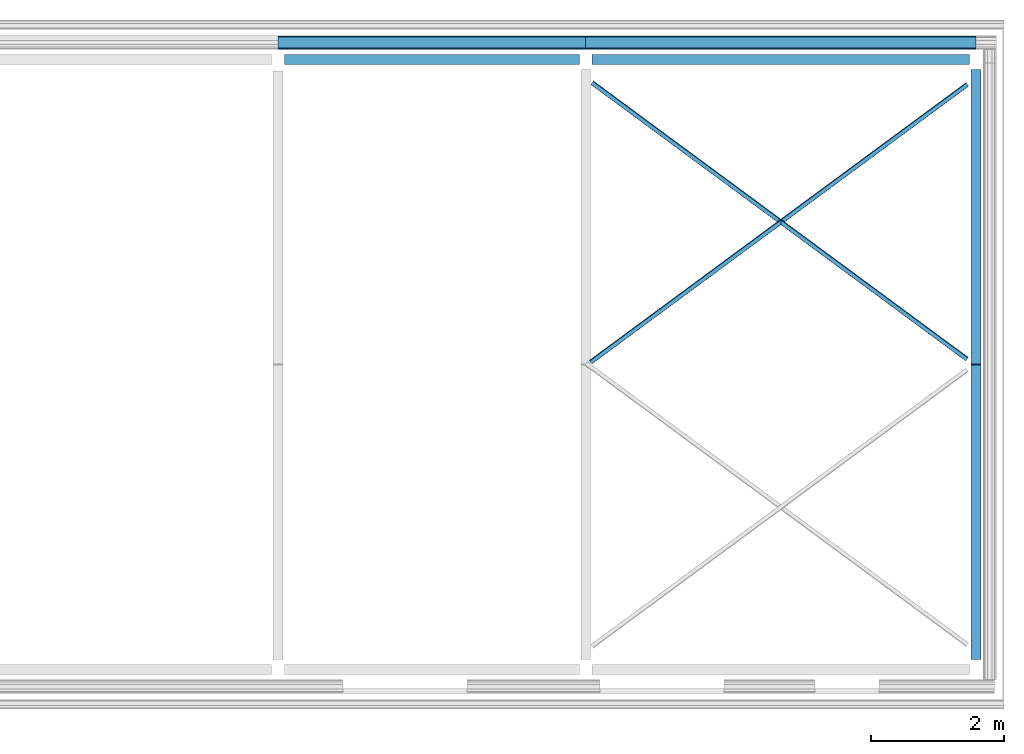
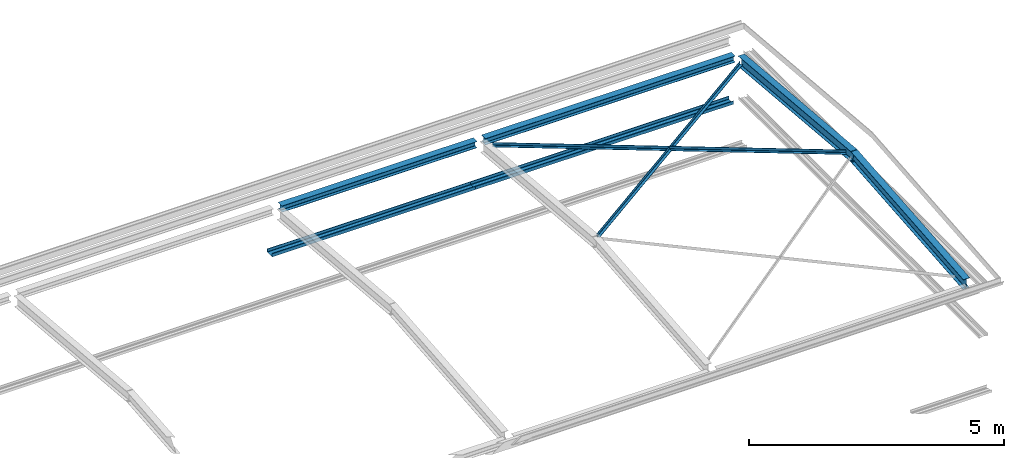
# One storey, part 3 of 8: 8 beams.
"""IFC2X3 building model written with IfcOpenShell, lengths in millimetres."""

from ifc_helpers import new_model, entity, si_unit, converted_unit, money_unit, point, direction, frame, frame_2d, origin_with_axes, place, context, subcontext, project, spatial, polyline, circle_curve, parameter, trimmed, segment, composite_curve, outline, extrude, clip, halfspace, material, type_object, element, save


model = new_model("IFC2X3")

# Units and contexts
model_context = context("Model", 3, precision=1e-05, world=origin_with_axes(), true_north=direction((0.0, 1.0)))
body_context = subcontext(model_context, "Body", "Model", "MODEL_VIEW")
ifc_project = project(units=[si_unit("LENGTHUNIT", "METRE", prefix="MILLI"), si_unit("AREAUNIT", "SQUARE_METRE"), si_unit("VOLUMEUNIT", "CUBIC_METRE"), converted_unit("PLANEANGLEUNIT", "DEGREE", entity("IfcPlaneAngleMeasure", 0.0174532925199), si_unit("PLANEANGLEUNIT", "RADIAN"), dimensions=[0, 0, 0, 0, 0, 0, 0]), si_unit("SOLIDANGLEUNIT", "STERADIAN"), money_unit("USD"), converted_unit("TIMEUNIT", "Year", entity("IfcTimeMeasure", 31556926.0), si_unit("TIMEUNIT", "SECOND"), dimensions=[0, 0, 0, 0, 0, 0, 0]), si_unit("MASSUNIT", "GRAM"), si_unit("THERMODYNAMICTEMPERATUREUNIT", "DEGREE_CELSIUS"), si_unit("LUMINOUSINTENSITYUNIT", "LUMEN")], contexts=[model_context])

# Site, building, storey
site_placement = place(None, origin_with_axes())
site = spatial("IfcSite", under=ifc_project, at=site_placement, CompositionType="ELEMENT")
building_placement = place(site_placement, origin_with_axes())
building = spatial("IfcBuilding", under=site, at=building_placement, CompositionType="ELEMENT")
storey_placement = place(building_placement, frame((0.0, 0.0, 74215.0), z_axis=(0.0, 0.0, 1.0), x_axis=(1.0, 0.0, 0.0)))
storey = spatial("IfcBuildingStorey", under=building, at=storey_placement, CompositionType="ELEMENT", Elevation=74215.0)

# Beams
ifc_material = material(Name="Metal - Steel 43-275")
beam_type_1 = type_object("IfcBeamType", Name="PFC200x75x23 (1) 75 x 200", PredefinedType="NOTDEFINED")
beam_1_placement = place(storey_placement, frame((10556.4431324, 8402.49616284, -1330.2), z_axis=(0.0, 0.0, 1.0), x_axis=(0.0, 1.0, 0.0)))
element("IfcBeam", 1, at=beam_1_placement, inside=storey, type_object=beam_type_1, material=ifc_material, Name="PFC-Parallel Flange Channels:PFC200x75x23", ObjectType="PFC-Parallel Flange Channels:PFC200x75x23", context=body_context, shape_type="SweptSolid", body=[
    extrude(outline(composite_curve([segment(polyline([(-40.2, -100.0), (34.8, -100.0), (34.8, 100.0), (-40.2, 100.0), (-40.2, 87.5), (16.8, 87.5)]), True, "CONTINUOUS"), segment(trimmed(circle_curve(frame_2d((16.8, 75.5), x_axis=(1.0, 0.0)), 12.0), [point((16.8, 87.5)), parameter(90.0)], [point((28.8, 75.5)), parameter(0.0)], False, "CARTESIAN"), True, "CONTINUOUS"), segment(polyline([(28.8, 75.5), (28.8, -75.5)]), True, "CONTINUOUS"), segment(trimmed(circle_curve(frame_2d((16.8, -75.5), x_axis=(0.0, -1.0)), 12.0), [point((28.8, -75.5)), parameter(90.0)], [point((16.8, -87.5)), parameter(0.0)], False, "CARTESIAN"), True, "CONTINUOUS"), segment(polyline([(16.8, -87.5), (-40.2, -87.5), (-40.2, -100.0)]), True, "CONTINUOUS")], self_intersect=False)), frame((0.0, 4610.24734375, 0.0), z_axis=(0.0, -1.0, 0.0), x_axis=(0.0, 0.0, -1.0)), (0.0, 0.0, 1.0), 4610.24734375),
])
beam_2_placement = place(storey_placement, frame((16408.2794762, 8402.49616284, -1330.2), z_axis=(0.0, 0.0, 1.0), x_axis=(0.0, 1.0, 0.0)))
element("IfcBeam", 2, at=beam_2_placement, inside=storey, type_object=beam_type_1, material=ifc_material, Name="PFC-Parallel Flange Channels:PFC200x75x23", ObjectType="PFC-Parallel Flange Channels:PFC200x75x23", context=body_context, shape_type="SweptSolid", body=[
    extrude(outline(composite_curve([segment(polyline([(-40.2, -100.0), (34.8, -100.0), (34.8, 100.0), (-40.2, 100.0), (-40.2, 87.5), (16.8, 87.5)]), True, "CONTINUOUS"), segment(trimmed(circle_curve(frame_2d((16.8, 75.5), x_axis=(1.0, 0.0)), 12.0), [point((16.8, 87.5)), parameter(90.0)], [point((28.8, 75.5)), parameter(0.0)], False, "CARTESIAN"), True, "CONTINUOUS"), segment(polyline([(28.8, 75.5), (28.8, -75.5)]), True, "CONTINUOUS"), segment(trimmed(circle_curve(frame_2d((16.8, -75.5), x_axis=(0.0, -1.0)), 12.0), [point((28.8, -75.5)), parameter(90.0)], [point((16.8, -87.5)), parameter(0.0)], False, "CARTESIAN"), True, "CONTINUOUS"), segment(polyline([(16.8, -87.5), (-40.2, -87.5), (-40.2, -100.0)]), True, "CONTINUOUS")], self_intersect=False)), frame((0.0, 5851.87535003, 0.0), z_axis=(0.0, -1.0, 0.0), x_axis=(0.0, 0.0, -1.0)), (0.0, 0.0, 1.0), 5851.87535003),
])
beam_type_2 = type_object("IfcBeamType", Name="UB254x146x31 (1) 251 x 146", PredefinedType="NOTDEFINED")
beam_3_placement = place(storey_placement, frame((16408.2794762, 3541.17069288, 267.014681752), z_axis=(0.0, 0.0, 1.0), x_axis=(1.0, 0.0, 0.0)))
element("IfcBeam", 3, at=beam_3_placement, inside=storey, type_object=beam_type_2, material=ifc_material, Name="UB-Universal Beams:UB254x146x31", ObjectType="UB-Universal Beams:UB254x146x31", context=body_context, shape_type="Clipping", body=[
    clip(clip(clip(clip(extrude(outline(composite_curve([segment(polyline([(125.7, 73.05), (117.1, 73.05), (117.1, 10.6)]), True, "CONTINUOUS"), segment(trimmed(circle_curve(frame_2d((109.5, 10.6), x_axis=(0.0, -1.0)), 7.6), [point((117.1, 10.6)), parameter(90.0)], [point((109.5, 3.0)), parameter(0.0)], False, "CARTESIAN"), True, "CONTINUOUS"), segment(polyline([(109.5, 3.0), (-109.5, 3.0)]), True, "CONTINUOUS"), segment(trimmed(circle_curve(frame_2d((-109.5, 10.6), x_axis=(-1.0, 0.0)), 7.6), [point((-109.5, 3.0)), parameter(90.0)], [point((-117.1, 10.6)), parameter(0.0)], False, "CARTESIAN"), True, "CONTINUOUS"), segment(polyline([(-117.1, 10.6), (-117.1, 73.05), (-125.7, 73.05), (-125.7, -73.05), (-117.1, -73.05), (-117.1, -10.6)]), True, "CONTINUOUS"), segment(trimmed(circle_curve(frame_2d((-109.5, -10.6), x_axis=(0.0, 1.0)), 7.6), [point((-117.1, -10.6)), parameter(90.0)], [point((-109.5, -3.0)), parameter(0.0)], False, "CARTESIAN"), True, "CONTINUOUS"), segment(polyline([(-109.5, -3.0), (109.5, -3.0)]), True, "CONTINUOUS"), segment(trimmed(circle_curve(frame_2d((109.5, -10.6), x_axis=(1.0, 0.0)), 7.6), [point((109.5, -3.0)), parameter(90.0)], [point((117.1, -10.6)), parameter(0.0)], False, "CARTESIAN"), True, "CONTINUOUS"), segment(polyline([(117.1, -10.6), (117.1, -73.05), (125.7, -73.05), (125.7, 73.05)]), True, "CONTINUOUS")], self_intersect=False)), frame((0.0, 4482.93411635, -395.427760455), z_axis=(0.0, -0.996132286365, 0.08786619408), x_axis=(0.0, -0.08786619408, -0.996132286365)), (0.0, 0.0, 1.0), 4518.56524717), halfspace(frame((0.0, 4446.62488753, -392.225019424), z_axis=(0.0, -0.996132286365, 0.08786619408), x_axis=(0.0, -0.08786619408, -0.996132286365)), True)), halfspace(frame((0.0, 18.1546144043, -1.60137051527), z_axis=(0.0, 0.996132286365, -0.08786619408), x_axis=(0.0, 0.08786619408, 0.996132286365)), True)), halfspace(frame((0.0, 4464.77950194, 0.0), z_axis=(0.0, -1.0, 0.0), x_axis=(0.0, 0.0, -1.0)), True)), halfspace(frame((0.0, 0.0, 0.0), z_axis=(0.0, 1.0, 0.0), x_axis=(0.0, 0.0, 1.0)), True)),
])
beam_4_placement = place(storey_placement, frame((16408.2794762, 3613.7891505, 267.014681752), z_axis=(0.0, 0.0, 1.0), x_axis=(-1.0, 0.0, 0.0)))
element("IfcBeam", 4, at=beam_4_placement, inside=storey, type_object=beam_type_2, material=ifc_material, Name="UB-Universal Beams:UB254x146x31", ObjectType="UB-Universal Beams:UB254x146x31", context=body_context, shape_type="Clipping", body=[
    clip(clip(clip(clip(extrude(outline(composite_curve([segment(polyline([(125.7, 73.05), (117.1, 73.05), (117.1, 10.6)]), True, "CONTINUOUS"), segment(trimmed(circle_curve(frame_2d((109.5, 10.6), x_axis=(0.0, -1.0)), 7.6), [point((117.1, 10.6)), parameter(90.0)], [point((109.5, 3.0)), parameter(0.0)], False, "CARTESIAN"), True, "CONTINUOUS"), segment(polyline([(109.5, 3.0), (-109.5, 3.0)]), True, "CONTINUOUS"), segment(trimmed(circle_curve(frame_2d((-109.5, 10.6), x_axis=(-1.0, 0.0)), 7.6), [point((-109.5, 3.0)), parameter(90.0)], [point((-117.1, 10.6)), parameter(0.0)], False, "CARTESIAN"), True, "CONTINUOUS"), segment(polyline([(-117.1, 10.6), (-117.1, 73.05), (-125.7, 73.05), (-125.7, -73.05), (-117.1, -73.05), (-117.1, -10.6)]), True, "CONTINUOUS"), segment(trimmed(circle_curve(frame_2d((-109.5, -10.6), x_axis=(0.0, 1.0)), 7.6), [point((-117.1, -10.6)), parameter(90.0)], [point((-109.5, -3.0)), parameter(0.0)], False, "CARTESIAN"), True, "CONTINUOUS"), segment(polyline([(-109.5, -3.0), (109.5, -3.0)]), True, "CONTINUOUS"), segment(trimmed(circle_curve(frame_2d((109.5, -10.6), x_axis=(1.0, 0.0)), 7.6), [point((109.5, -3.0)), parameter(90.0)], [point((117.1, -10.6)), parameter(0.0)], False, "CARTESIAN"), True, "CONTINUOUS"), segment(polyline([(117.1, -10.6), (117.1, -73.05), (125.7, -73.05), (125.7, 73.05)]), True, "CONTINUOUS")], self_intersect=False)), frame((0.0, 4482.93411635, -395.427760455), z_axis=(0.0, -0.996132286365, 0.08786619408), x_axis=(0.0, -0.08786619408, -0.996132286365)), (0.0, 0.0, 1.0), 4518.56524717), halfspace(frame((0.0, 4446.62488753, -392.225019424), z_axis=(0.0, -0.996132286365, 0.08786619408), x_axis=(0.0, -0.08786619408, -0.996132286365)), True)), halfspace(frame((0.0, 18.1546144043, -1.60137051527), z_axis=(0.0, 0.996132286365, -0.08786619408), x_axis=(0.0, 0.08786619408, 0.996132286365)), True)), halfspace(frame((0.0, 4464.77950194, 0.0), z_axis=(0.0, -1.0, 0.0), x_axis=(0.0, 0.0, -1.0)), True)), halfspace(frame((0.0, 0.0, 0.0), z_axis=(0.0, 1.0, 0.0), x_axis=(0.0, 0.0, 1.0)), True)),
])
beam_type_3 = type_object("IfcBeamType", Name="UC152x152x23 152 x 152", PredefinedType="NOTDEFINED")
beam_5_placement = place(storey_placement, frame((10461.1999574, 8150.57993509, -116.2), z_axis=(0.0, 0.0, 1.0), x_axis=(0.0, 1.0, 0.0)))
element("IfcBeam", 5, at=beam_5_placement, inside=storey, type_object=beam_type_3, material=ifc_material, Name="UC-Universal Columns:UC152x152x23", ObjectType="UC-Universal Columns:UC152x152x23", context=body_context, shape_type="SweptSolid", body=[
    extrude(outline(composite_curve([segment(polyline([(76.2, 76.1), (69.4, 76.1), (69.4, 10.4999999999)]), True, "CONTINUOUS"), segment(trimmed(circle_curve(frame_2d((61.8, 10.4999999999), x_axis=(0.0, -1.0)), 7.60000000002), [point((69.4, 10.4999999999)), parameter(90.0)], [point((61.8, 2.89999999987)), parameter(0.0)], False, "CARTESIAN"), True, "CONTINUOUS"), segment(polyline([(61.8, 2.89999999987), (-61.8, 2.89999999987)]), True, "CONTINUOUS"), segment(trimmed(circle_curve(frame_2d((-61.8, 10.4999999999), x_axis=(-1.0, 0.0)), 7.60000000002), [point((-61.8, 2.89999999987)), parameter(90.0)], [point((-69.4, 10.4999999999)), parameter(0.0)], False, "CARTESIAN"), True, "CONTINUOUS"), segment(polyline([(-69.4, 10.4999999999), (-69.4, 76.1), (-76.2, 76.1), (-76.2, -76.1), (-69.4, -76.1), (-69.4, -10.4999999999)]), True, "CONTINUOUS"), segment(trimmed(circle_curve(frame_2d((-61.8, -10.4999999999), x_axis=(0.0, 1.0)), 7.60000000002), [point((-69.4, -10.4999999999)), parameter(90.0)], [point((-61.8, -2.89999999987)), parameter(0.0)], False, "CARTESIAN"), True, "CONTINUOUS"), segment(polyline([(-61.8, -2.89999999987), (61.8, -2.89999999987)]), True, "CONTINUOUS"), segment(trimmed(circle_curve(frame_2d((61.8, -10.4999999999), x_axis=(1.0, 0.0)), 7.60000000002), [point((61.8, -2.89999999987)), parameter(90.0)], [point((69.4, -10.4999999999)), parameter(0.0)], False, "CARTESIAN"), True, "CONTINUOUS"), segment(polyline([(69.4, -10.4999999999), (69.4, -76.1), (76.2, -76.1), (76.2, 76.1)]), True, "CONTINUOUS")], self_intersect=False)), frame((0.0, 4419.8, 0.0), z_axis=(0.0, -1.0, 0.0), x_axis=(0.0, 0.0, -1.0)), (0.0, 0.0, 1.0), 4419.8),
])
beam_6_placement = place(storey_placement, frame((16313.0418012, 8150.57993509, -116.2), z_axis=(0.0, 0.0, 1.0), x_axis=(0.0, 1.0, 0.0)))
element("IfcBeam", 6, at=beam_6_placement, inside=storey, type_object=beam_type_3, material=ifc_material, Name="UC-Universal Columns:UC152x152x23", ObjectType="UC-Universal Columns:UC152x152x23", context=body_context, shape_type="SweptSolid", body=[
    extrude(outline(composite_curve([segment(polyline([(76.2, 76.1), (69.4, 76.1), (69.4, 10.4999999999)]), True, "CONTINUOUS"), segment(trimmed(circle_curve(frame_2d((61.8, 10.4999999999), x_axis=(0.0, -1.0)), 7.60000000002), [point((69.4, 10.4999999999)), parameter(90.0)], [point((61.8, 2.89999999987)), parameter(0.0)], False, "CARTESIAN"), True, "CONTINUOUS"), segment(polyline([(61.8, 2.89999999987), (-61.8, 2.89999999987)]), True, "CONTINUOUS"), segment(trimmed(circle_curve(frame_2d((-61.8, 10.4999999999), x_axis=(-1.0, 0.0)), 7.60000000002), [point((-61.8, 2.89999999987)), parameter(90.0)], [point((-69.4, 10.4999999999)), parameter(0.0)], False, "CARTESIAN"), True, "CONTINUOUS"), segment(polyline([(-69.4, 10.4999999999), (-69.4, 76.1), (-76.2, 76.1), (-76.2, -76.1), (-69.4, -76.1), (-69.4, -10.4999999999)]), True, "CONTINUOUS"), segment(trimmed(circle_curve(frame_2d((-61.8, -10.4999999999), x_axis=(0.0, 1.0)), 7.60000000002), [point((-69.4, -10.4999999999)), parameter(90.0)], [point((-61.8, -2.89999999987)), parameter(0.0)], False, "CARTESIAN"), True, "CONTINUOUS"), segment(polyline([(-61.8, -2.89999999987), (61.8, -2.89999999987)]), True, "CONTINUOUS"), segment(trimmed(circle_curve(frame_2d((61.8, -10.4999999999), x_axis=(1.0, 0.0)), 7.60000000002), [point((61.8, -2.89999999987)), parameter(90.0)], [point((69.4, -10.4999999999)), parameter(0.0)], False, "CARTESIAN"), True, "CONTINUOUS"), segment(polyline([(69.4, -10.4999999999), (69.4, -76.1), (76.2, -76.1), (76.2, 76.1)]), True, "CONTINUOUS")], self_intersect=False)), frame((0.0, 5661.4, 0.0), z_axis=(0.0, -1.0, 0.0), x_axis=(0.0, 0.0, -1.0)), (0.0, 0.0, 1.0), 5661.4),
])
beam_type_4 = type_object("IfcBeamType", Name="L70x70x7 70 x 70", PredefinedType="NOTDEFINED")
beam_7_placement = place(storey_placement, frame((16281.1286039, 3662.8524024, 338.375505027), z_axis=(0.0, 0.0, 1.0), x_axis=(0.593453056402, 0.804868604089, 0.0)))
element("IfcBeam", 7, at=beam_7_placement, inside=storey, type_object=beam_type_4, material=ifc_material, Name="L-Equal Leg Angles:L70x70x7", ObjectType="L-Equal Leg Angles:L70x70x7", context=body_context, shape_type="Clipping", body=[
    clip(clip(clip(clip(extrude(outline(composite_curve([segment(polyline([(23.9444444444, -43.5555555556), (26.4444444444, -43.5555555556), (26.4444444444, 26.4444444444), (-43.5555555556, 26.4444444445), (-43.5555555556, 23.9444444445)]), True, "CONTINUOUS"), segment(trimmed(circle_curve(frame_2d((-39.0555555556, 23.9444444445), x_axis=(-1.0, 0.0)), 4.5), [point((-43.5555555556, 23.9444444445)), parameter(0.0)], [point((-39.0555555555, 19.4444444445)), parameter(90.0000000013)], True, "CARTESIAN"), True, "CONTINUOUS"), segment(polyline([(-39.0555555555, 19.4444444445), (10.4444444444, 19.4444444444)]), True, "CONTINUOUS"), segment(trimmed(circle_curve(frame_2d((10.4444444444, 10.4444444444), x_axis=(1.0, 0.0)), 9.0), [point((10.4444444444, 19.4444444444)), parameter(90.0)], [point((19.4444444444, 10.4444444444)), parameter(0.0)], False, "CARTESIAN"), True, "CONTINUOUS"), segment(polyline([(19.4444444444, 10.4444444444), (19.4444444444, -39.0555555556)]), True, "CONTINUOUS"), segment(trimmed(circle_curve(frame_2d((23.9444444444, -39.0555555556), x_axis=(-1.0, 0.0)), 4.5), [point((19.4444444444, -39.0555555556)), parameter(0.0)], [point((23.9444444444, -43.5555555556)), parameter(90.0)], True, "CARTESIAN"), True, "CONTINUOUS")], self_intersect=False)), frame((0.0, 6997.76516264, -366.311483548), z_axis=(0.0, -0.998632709103, 0.0522753508711), x_axis=(0.0, -0.0522753508711, -0.998632709103)), (0.0, 0.0, 1.0), 7012.5283245), halfspace(frame((0.0, 6987.41517122, -365.76969333), z_axis=(0.0, -0.998632709103, 0.0522753508711), x_axis=(0.0, -0.0522753508711, -0.998632709103)), True)), halfspace(frame((0.0, 5.17499571258, -0.270895109048), z_axis=(0.0, 0.998632709103, -0.0522753508711), x_axis=(0.0, 0.0522753508711, 0.998632709103)), True)), halfspace(frame((0.0, 6992.59016693, 0.0), z_axis=(0.0, -1.0, 0.0), x_axis=(0.0, 0.0, -1.0)), True)), halfspace(frame((0.0, 0.0, 0.0), z_axis=(0.0, 1.0, 0.0), x_axis=(0.0, 0.0, 1.0)), True)),
])
beam_type_5 = type_object("IfcBeamType", Name="L70x70x7 (1) 70 x 70", PredefinedType="NOTDEFINED")
beam_8_placement = place(storey_placement, frame((10622.6332553, 3617.84127034, 342.345817926), z_axis=(0.0, 0.0, 1.0), x_axis=(0.593453056402, -0.804868604089, 0.0)))
element("IfcBeam", 8, at=beam_8_placement, inside=storey, type_object=beam_type_5, material=ifc_material, Name="L-Equal Leg Angles:L70x70x7", ObjectType="L-Equal Leg Angles:L70x70x7", context=body_context, shape_type="Clipping", body=[
    clip(clip(clip(clip(extrude(outline(composite_curve([segment(polyline([(-43.5555555556, -26.4444444444), (26.4444444444, -26.4444444444), (26.4444444444, 43.5555555556), (23.9444444444, 43.5555555556)]), True, "CONTINUOUS"), segment(trimmed(circle_curve(frame_2d((23.9444444444, 39.0555555556), x_axis=(0.0, 1.0)), 4.5), [point((23.9444444444, 43.5555555556)), parameter(0.0)], [point((19.4444444444, 39.0555555555)), parameter(90.0000000013)], True, "CARTESIAN"), True, "CONTINUOUS"), segment(polyline([(19.4444444444, 39.0555555555), (19.4444444444, -10.4444444444)]), True, "CONTINUOUS"), segment(trimmed(circle_curve(frame_2d((10.4444444444, -10.4444444444), x_axis=(0.0, -1.0)), 9.0), [point((19.4444444444, -10.4444444444)), parameter(90.0)], [point((10.4444444444, -19.4444444444)), parameter(0.0)], False, "CARTESIAN"), True, "CONTINUOUS"), segment(polyline([(10.4444444444, -19.4444444444), (-39.0555555556, -19.4444444444)]), True, "CONTINUOUS"), segment(trimmed(circle_curve(frame_2d((-39.0555555556, -23.9444444443), x_axis=(0.0, 1.0)), 4.49999999995), [point((-39.0555555556, -19.4444444444)), parameter(0.0)], [point((-43.5555555555, -23.9444444445)), parameter(90.0000000013)], True, "CARTESIAN"), True, "CONTINUOUS"), segment(polyline([(-43.5555555555, -23.9444444445), (-43.5555555556, -26.4444444444)]), True, "CONTINUOUS")], self_intersect=False)), frame((0.0, 7031.2193584, -368.062707802), z_axis=(0.0, -0.998632709103, 0.0522753508711), x_axis=(0.0, -0.0522753508711, -0.998632709103)), (0.0, 0.0, 1.0), 7046.0283245), halfspace(frame((0.0, 7020.86936698, -367.520917584), z_axis=(0.0, -0.998632709103, 0.0522753508711), x_axis=(0.0, -0.0522753508711, -0.998632709103)), True)), halfspace(frame((0.0, 5.17499571258, -0.270895109048), z_axis=(0.0, 0.998632709103, -0.0522753508711), x_axis=(0.0, 0.0522753508711, 0.998632709103)), True)), halfspace(frame((0.0, 7026.04436269, 0.0), z_axis=(0.0, -1.0, 0.0), x_axis=(0.0, 0.0, -1.0)), True)), halfspace(frame((0.0, 0.0, 0.0), z_axis=(0.0, 1.0, 0.0), x_axis=(0.0, 0.0, 1.0)), True)),
])

save(model, "model.ifc")
